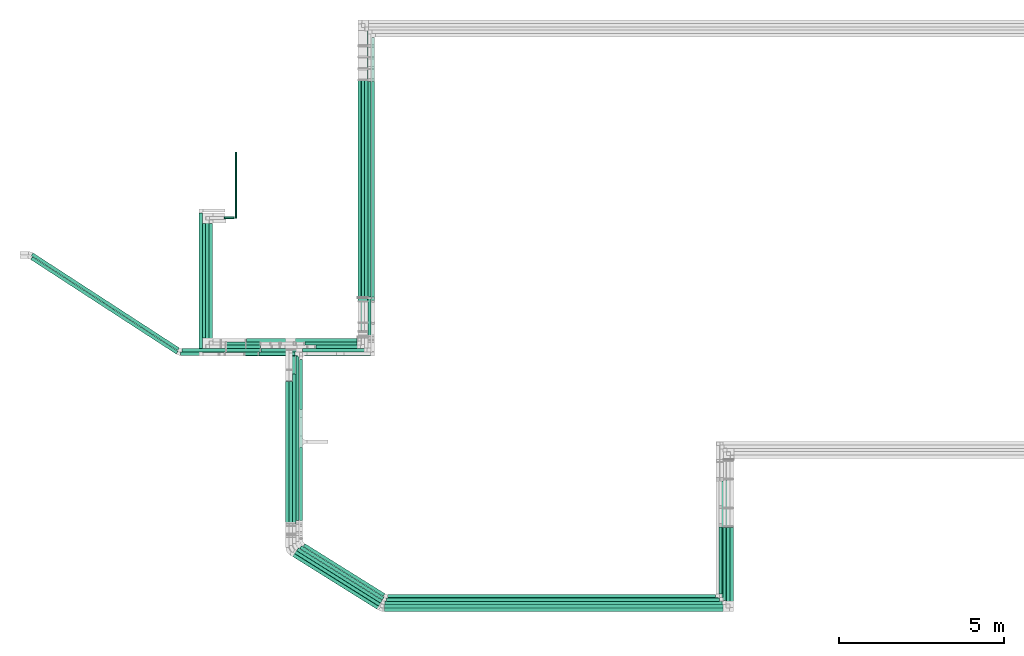
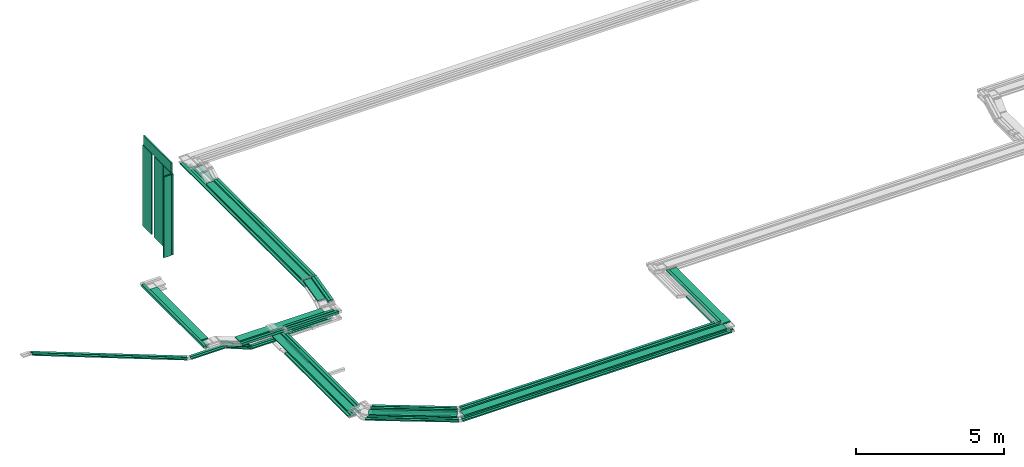
# One storey, part 1 of 18: 64 flow segments.
"""IFC2X3 building model written with IfcOpenShell, lengths in millimetres."""

from ifc_helpers import new_model, entity, si_unit, converted_unit, derived_unit, direction, frame, frame_2d, origin, origin_2d_with_axis, place, context, subcontext, project, spatial, rectangle, extrude, type_object, element, save


model = new_model("IFC2X3")

# Units and contexts
model_context = context("Model", 3, precision=0.01, world=origin(), true_north=direction((6.12303176911189e-17, 1.0)))
body_context = subcontext(model_context, "Body", "Model", "MODEL_VIEW")
ifc_project = project(units=[si_unit("LENGTHUNIT", "METRE", prefix="MILLI"), si_unit("AREAUNIT", "SQUARE_METRE"), si_unit("VOLUMEUNIT", "CUBIC_METRE"), converted_unit("PLANEANGLEUNIT", "DEGREE", entity("IfcRatioMeasure", 0.0174532925199433), si_unit("PLANEANGLEUNIT", "RADIAN"), dimensions=[0, 0, 0, 0, 0, 0, 0]), si_unit("MASSUNIT", "GRAM", prefix="KILO"), derived_unit("MASSDENSITYUNIT", [(si_unit("MASSUNIT", "GRAM", prefix="KILO"), 1), (si_unit("LENGTHUNIT", "METRE"), -3)]), derived_unit("MOMENTOFINERTIAUNIT", [(si_unit("LENGTHUNIT", "METRE"), 4)]), si_unit("TIMEUNIT", "SECOND"), si_unit("FREQUENCYUNIT", "HERTZ"), si_unit("THERMODYNAMICTEMPERATUREUNIT", "DEGREE_CELSIUS"), derived_unit("THERMALTRANSMITTANCEUNIT", [(si_unit("MASSUNIT", "GRAM", prefix="KILO"), 1), (si_unit("THERMODYNAMICTEMPERATUREUNIT", "KELVIN"), -1), (si_unit("TIMEUNIT", "SECOND"), -3)]), derived_unit("VOLUMETRICFLOWRATEUNIT", [(si_unit("LENGTHUNIT", "METRE"), 3), (si_unit("TIMEUNIT", "SECOND"), -1)]), derived_unit("MASSFLOWRATEUNIT", [(si_unit("MASSUNIT", "GRAM", prefix="KILO"), 1), (si_unit("TIMEUNIT", "SECOND"), -1)]), derived_unit("ROTATIONALFREQUENCYUNIT", [(si_unit("TIMEUNIT", "SECOND"), -1)]), si_unit("ELECTRICCURRENTUNIT", "AMPERE"), si_unit("ELECTRICVOLTAGEUNIT", "VOLT"), si_unit("POWERUNIT", "WATT"), si_unit("FORCEUNIT", "NEWTON", prefix="KILO"), si_unit("ILLUMINANCEUNIT", "LUX"), si_unit("LUMINOUSFLUXUNIT", "LUMEN"), si_unit("LUMINOUSINTENSITYUNIT", "CANDELA"), derived_unit("USERDEFINED", [(si_unit("MASSUNIT", "GRAM", prefix="KILO"), -1), (si_unit("LENGTHUNIT", "METRE"), -2), (si_unit("TIMEUNIT", "SECOND"), 3), (si_unit("LUMINOUSFLUXUNIT", "LUMEN"), 1)]), derived_unit("LINEARVELOCITYUNIT", [(si_unit("LENGTHUNIT", "METRE"), 1), (si_unit("TIMEUNIT", "SECOND"), -1)]), si_unit("PRESSUREUNIT", "PASCAL"), derived_unit("USERDEFINED", [(si_unit("LENGTHUNIT", "METRE"), -2), (si_unit("MASSUNIT", "GRAM", prefix="KILO"), 1), (si_unit("TIMEUNIT", "SECOND"), -2)]), derived_unit("LINEARFORCEUNIT", [(si_unit("MASSUNIT", "GRAM", prefix="KILO"), 1), (si_unit("LENGTHUNIT", "METRE"), 1), (si_unit("TIMEUNIT", "SECOND"), -2), (si_unit("LENGTHUNIT", "METRE"), -1)]), derived_unit("PLANARFORCEUNIT", [(si_unit("MASSUNIT", "GRAM", prefix="KILO"), 1), (si_unit("LENGTHUNIT", "METRE"), 1), (si_unit("TIMEUNIT", "SECOND"), -2), (si_unit("LENGTHUNIT", "METRE"), -2)])], contexts=[model_context])

# Site, building, storey
site_placement = place(None, frame((0.0, -0.00077364408347762, 0.0)))
site = spatial("IfcSite", under=ifc_project, at=site_placement, CompositionType="ELEMENT")
building_placement = place(site_placement, origin())
building = spatial("IfcBuilding", under=site, at=building_placement, CompositionType="ELEMENT")
storey_placement = place(building_placement, frame((0.0, 0.0, 19800.0)))
storey = spatial("IfcBuildingStorey", under=building, at=storey_placement, CompositionType="ELEMENT", Elevation=19800.0)

# Flow segments
cable_carrier_segment_type_1 = type_object("IfcCableCarrierSegmentType", PredefinedType="CABLETRAYSEGMENT")
flow_segment_1_placement = place(storey_placement, frame((20190.2168010831, 11603.0012765651, 3300.0)))
element("IfcFlowSegment", 1, at=flow_segment_1_placement, inside=storey, type_object=cable_carrier_segment_type_1, context=body_context, shape_type="SweptSolid", body=[
    extrude(rectangle(XDim=6551.54787533766, YDim=300.000000000001, at=frame_2d((9.09494701772928e-13, -2.17426077142591e-12), x_axis=(1.0, 0.0))), frame((150.0, 3275.77393766883, 0.0), z_axis=(0.0, 0.0, 1.0), x_axis=(0.0, 1.0, 0.0)), (0.0, 0.0, 1.0), 49.9999999999973),
])
flow_segment_2_placement = place(storey_placement, frame((20495.2168010831, 11609.1230030289, 3300.0)))
element("IfcFlowSegment", 2, at=flow_segment_2_placement, inside=storey, type_object=cable_carrier_segment_type_1, context=body_context, shape_type="SweptSolid", body=[
    extrude(rectangle(XDim=6531.55992167095, YDim=100.000000000003, at=frame_2d((1.13686837721616e-12, -2.16715534406831e-12), x_axis=(1.0, 0.0))), frame((50.0, 3265.77996083547, 0.0), z_axis=(0.0, 0.0, 1.0), x_axis=(0.0, 1.0, 0.0)), (0.0, 0.0, 1.0), 100.000000000003),
])
flow_segment_3_placement = place(storey_placement, frame((20600.2168010831, 11501.2511492112, 3100.0)))
element("IfcFlowSegment", 3, at=flow_segment_3_placement, inside=storey, type_object=cable_carrier_segment_type_1, context=body_context, shape_type="SweptSolid", body=[
    extrude(rectangle(XDim=7968.74949015567, YDim=100.000000000003, at=frame_2d((0.0, -2.16715534406831e-12), x_axis=(1.0, 0.0))), frame((50.0, 3984.37474507783, 0.0), z_axis=(0.0, 0.0, 1.0), x_axis=(0.0, -1.0, 0.0)), (0.0, 0.0, 1.0), 100.000000000003),
])
flow_segment_4_placement = place(storey_placement, frame((20190.2168010831, 11493.5128111901, 3100.0)))
element("IfcFlowSegment", 4, at=flow_segment_4_placement, inside=storey, type_object=cable_carrier_segment_type_1, context=body_context, shape_type="SweptSolid", body=[
    extrude(rectangle(XDim=8386.48782817678, YDim=100.000000000003, at=frame_2d((9.09494701772928e-13, -2.16715534406831e-12), x_axis=(1.0, 0.0))), frame((50.0, 4193.24391408839, 0.0), z_axis=(0.0, 0.0, 1.0), x_axis=(0.0, -1.0, 0.0)), (0.0, 0.0, 1.0), 49.9999999999973),
])
flow_segment_5_placement = place(storey_placement, frame((20295.2168010831, 11493.5128111901, 3100.0)))
element("IfcFlowSegment", 5, at=flow_segment_5_placement, inside=storey, type_object=cable_carrier_segment_type_1, context=body_context, shape_type="SweptSolid", body=[
    extrude(rectangle(XDim=8281.48782817677, YDim=100.000000000003, at=frame_2d((9.09494701772928e-13, 0.0), x_axis=(1.0, 0.0))), frame((50.0, 4140.74391408839, 0.0), z_axis=(0.0, 0.0, 1.0), x_axis=(0.0, -1.0, 0.0)), (0.0, 0.0, 1.0), 49.9999999999973),
])
flow_segment_6_placement = place(storey_placement, frame((20400.2168010831, 11493.5128111901, 3100.0)))
element("IfcFlowSegment", 6, at=flow_segment_6_placement, inside=storey, type_object=cable_carrier_segment_type_1, context=body_context, shape_type="SweptSolid", body=[
    extrude(rectangle(XDim=8176.48782817679, YDim=100.000000000003, at=frame_2d((0.0, 2.16715534406831e-12), x_axis=(1.0, 0.0))), frame((50.0, 4088.2439140884, 0.0), z_axis=(0.0, 0.0, 1.0), x_axis=(0.0, -1.0, 0.0)), (0.0, 0.0, 1.0), 49.9999999999973),
])
flow_segment_7_placement = place(storey_placement, frame((18157.5440474966, 10050.1297639901, 2900.0)))
element("IfcFlowSegment", 7, at=flow_segment_7_placement, inside=storey, type_object=cable_carrier_segment_type_1, context=body_context, shape_type="SweptSolid", body=[
    extrude(rectangle(XDim=2012.67275358651, YDim=300.000000000001, at=frame_2d((-1.08002495835535e-12, 0.0), x_axis=(1.0, 0.0))), frame((1006.33637679325, 150.0, 0.0), z_axis=(0.0, 0.0, 1.0), x_axis=(-1.0, 0.0, 0.0)), (0.0, 0.0, 1.0), 49.9999999999973),
])
flow_segment_8_placement = place(storey_placement, frame((18522.1440474967, 9944.23549574398, 2900.0)))
element("IfcFlowSegment", 8, at=flow_segment_8_placement, inside=storey, type_object=cable_carrier_segment_type_1, context=body_context, shape_type="SweptSolid", body=[
    extrude(rectangle(XDim=1953.07275358647, YDim=99.9999999999989, at=frame_2d((0.0, 1.08357767203415e-12), x_axis=(1.0, 0.0))), frame((976.536376793235, 50.0, 0.0), z_axis=(0.0, 0.0, 1.0), x_axis=(-1.0, 0.0, 0.0)), (0.0, 0.0, 1.0), 100.000000000003),
])
flow_segment_9_placement = place(storey_placement, frame((16789.0007686029, 9824.22079653058, 2900.0)))
element("IfcFlowSegment", 9, at=flow_segment_9_placement, inside=storey, type_object=cable_carrier_segment_type_1, context=body_context, shape_type="SweptSolid", body=[
    extrude(rectangle(XDim=1677.74327889368, YDim=99.9999999999989, at=frame_2d((1.08002495835535e-12, 0.0), x_axis=(1.0, 0.0))), frame((838.871639446842, 50.0, 0.0)), (0.0, 0.0, 1.0), 100.000000000003),
])
flow_segment_10_placement = place(storey_placement, frame((17191.3522289193, 9840.22583236336, 2600.0)))
element("IfcFlowSegment", 10, at=flow_segment_10_placement, inside=storey, type_object=cable_carrier_segment_type_1, context=body_context, shape_type="SweptSolid", body=[
    extrude(rectangle(XDim=1095.79181857732, YDim=99.9999999999989, at=frame_2d((1.08002495835535e-12, 0.0), x_axis=(1.0, 0.0))), frame((547.895909288659, 50.0, 0.0)), (0.0, 0.0, 1.0), 49.9999999999973),
])
flow_segment_11_placement = place(storey_placement, frame((17256.5890277902, 9944.23549574399, 2600.0)))
element("IfcFlowSegment", 11, at=flow_segment_11_placement, inside=storey, type_object=cable_carrier_segment_type_1, context=body_context, shape_type="SweptSolid", body=[
    extrude(rectangle(XDim=3123.62777329295, YDim=99.9999999999989, at=frame_2d((1.13686837721616e-12, 0.0), x_axis=(1.0, 0.0))), frame((1561.81388664648, 50.0, 0.0), z_axis=(0.0, 0.0, 1.0), x_axis=(-1.0, 0.0, 0.0)), (0.0, 0.0, 1.0), 50.0000000000016),
])
flow_segment_12_placement = place(storey_placement, frame((21062.5934276672, 2392.26804939264, 3200.0)))
element("IfcFlowSegment", 12, at=flow_segment_12_placement, inside=storey, type_object=cable_carrier_segment_type_1, context=body_context, shape_type="SweptSolid", body=[
    extrude(rectangle(XDim=10078.0137037583, YDim=100.0, at=origin_2d_with_axis()), frame((5039.00685187917, 50.0, 0.0), z_axis=(0.0, 0.0, 1.0), x_axis=(-1.0, 0.0, 0.0)), (0.0, 0.0, 1.0), 100.000000000008),
])
flow_segment_13_placement = place(storey_placement, frame((20986.6526743411, 2192.26804939263, 3000.0)))
element("IfcFlowSegment", 13, at=flow_segment_13_placement, inside=storey, type_object=cable_carrier_segment_type_1, context=body_context, shape_type="SweptSolid", body=[
    extrude(rectangle(XDim=10354.846485042, YDim=100.0, at=frame_2d((1.81898940354586e-12, 1.3855583347322e-13), x_axis=(1.0, 0.0))), frame((5177.42324252102, 50.0, 0.0), z_axis=(0.0, 0.0, 1.0), x_axis=(-1.0, 0.0, 0.0)), (0.0, 0.0, 1.0), 49.9999999999973),
])
flow_segment_14_placement = place(storey_placement, frame((18007.1440474966, 4795.40856656226, 2800.0)))
element("IfcFlowSegment", 14, at=flow_segment_14_placement, inside=storey, type_object=cable_carrier_segment_type_1, context=body_context, shape_type="SweptSolid", body=[
    extrude(rectangle(XDim=5199.72119742787, YDim=300.000000000001, at=frame_2d((4.54747350886464e-13, 0.0), x_axis=(1.0, 0.0))), frame((150.0, 2599.86059871393, 0.0), z_axis=(0.0, 0.0, 1.0), x_axis=(0.0, 1.0, 0.0)), (0.0, 0.0, 1.0), 49.9999999999973),
])
flow_segment_15_placement = place(storey_placement, frame((18312.1440474966, 4839.9270477843, 2800.0)))
element("IfcFlowSegment", 15, at=flow_segment_15_placement, inside=storey, type_object=cable_carrier_segment_type_1, context=body_context, shape_type="SweptSolid", body=[
    extrude(rectangle(XDim=5127.14874316907, YDim=99.9999999999989, at=frame_2d((-2.27373675443232e-13, 0.0), x_axis=(1.0, 0.0))), frame((50.0, 2563.57437158454, 0.0), z_axis=(0.0, 0.0, 1.0), x_axis=(0.0, 1.0, 0.0)), (0.0, 0.0, 1.0), 100.000000000003),
])
flow_segment_16_placement = place(storey_placement, frame((18417.1440474966, 8193.9505516651, 2600.0)))
element("IfcFlowSegment", 16, at=flow_segment_16_placement, inside=storey, type_object=cable_carrier_segment_type_1, context=body_context, shape_type="SweptSolid", body=[
    extrude(rectangle(XDim=1516.27528069827, YDim=99.9999999999989, at=frame_2d((0.0, -1.08357767203415e-12), x_axis=(1.0, 0.0))), frame((50.0, 758.137640349134, 0.0), z_axis=(0.0, 0.0, 1.0), x_axis=(0.0, -1.0, 0.0)), (0.0, 0.0, 1.0), 50.0000000000016),
])
flow_segment_17_placement = place(storey_placement, frame((18007.1440474966, 4732.08348247397, 2600.0)))
element("IfcFlowSegment", 17, at=flow_segment_17_placement, inside=storey, type_object=cable_carrier_segment_type_1, context=body_context, shape_type="SweptSolid", body=[
    extrude(rectangle(XDim=4319.69591813559, YDim=99.9999999999989, at=frame_2d((6.82121026329696e-13, 0.0), x_axis=(1.0, 0.0))), frame((50.0, 2159.8479590678, 0.0), z_axis=(0.0, 0.0, 1.0), x_axis=(0.0, 1.0, 0.0)), (0.0, 0.0, 1.0), 49.9999999999973),
])
flow_segment_18_placement = place(storey_placement, frame((18112.1440474966, 4732.08348247398, 2600.0)))
element("IfcFlowSegment", 18, at=flow_segment_18_placement, inside=storey, type_object=cable_carrier_segment_type_1, context=body_context, shape_type="SweptSolid", body=[
    extrude(rectangle(XDim=4319.6959181356, YDim=99.9999999999989, at=origin_2d_with_axis()), frame((50.0, 2159.8479590678, 0.0), z_axis=(0.0, 0.0, 1.0), x_axis=(0.0, 1.0, 0.0)), (0.0, 0.0, 1.0), 49.9999999999973),
])
flow_segment_19_placement = place(storey_placement, frame((18217.1440474966, 4732.08348247398, 2600.0)))
element("IfcFlowSegment", 19, at=flow_segment_19_placement, inside=storey, type_object=cable_carrier_segment_type_1, context=body_context, shape_type="SweptSolid", body=[
    extrude(rectangle(XDim=4546.36734918782, YDim=99.9999999999989, at=origin_2d_with_axis()), frame((50.0, 2273.18367459391, 0.0), z_axis=(0.0, 0.0, 1.0), x_axis=(0.0, 1.0, 0.0)), (0.0, 0.0, 1.0), 49.9999999999973),
])
flow_segment_20_placement = place(storey_placement, frame((31125.1088789037, 2617.26804939265, 3000.0)))
element("IfcFlowSegment", 20, at=flow_segment_20_placement, inside=storey, type_object=cable_carrier_segment_type_1, context=body_context, shape_type="SweptSolid", body=[
    extrude(rectangle(XDim=2031.89362716771, YDim=100.000000000003, at=frame_2d((-2.27373675443232e-13, 2.16715534406831e-12), x_axis=(1.0, 0.0))), frame((50.0, 1015.94681358385, 0.0), z_axis=(0.0, 0.0, 1.0), x_axis=(0.0, 1.0, 0.0)), (0.0, 0.0, 1.0), 99.9999999999989),
])
flow_segment_21_placement = place(storey_placement, frame((31249.2859471786, 2417.26804939264, 3000.0)))
element("IfcFlowSegment", 21, at=flow_segment_21_placement, inside=storey, type_object=cable_carrier_segment_type_1, context=body_context, shape_type="SweptSolid", body=[
    extrude(rectangle(XDim=2211.95486644315, YDim=100.000000000003, at=frame_2d((2.27373675443232e-13, -2.16715534406831e-12), x_axis=(1.0, 0.0))), frame((50.0, 1105.97743322157, 0.0), z_axis=(0.0, 0.0, 1.0), x_axis=(0.0, 1.0, 0.0)), (0.0, 0.0, 1.0), 49.9999999999973),
])
flow_segment_22_placement = place(storey_placement, frame((31361.4991593832, 2312.26804939263, 3000.0)))
element("IfcFlowSegment", 22, at=flow_segment_22_placement, inside=storey, type_object=cable_carrier_segment_type_1, context=body_context, shape_type="SweptSolid", body=[
    extrude(rectangle(XDim=2316.95486644316, YDim=100.000000000003, at=frame_2d((-2.27373675443232e-13, 0.0), x_axis=(1.0, 0.0))), frame((50.0, 1158.47743322158, 0.0), z_axis=(0.0, 0.0, 1.0), x_axis=(0.0, -1.0, 0.0)), (0.0, 0.0, 1.0), 49.9999999999973),
])
flow_segment_23_placement = place(storey_placement, frame((31471.4335639594, 2207.26804939264, 3000.0)))
element("IfcFlowSegment", 23, at=flow_segment_23_placement, inside=storey, type_object=cable_carrier_segment_type_1, context=body_context, shape_type="SweptSolid", body=[
    extrude(rectangle(XDim=2421.95486644317, YDim=100.000000000003, at=frame_2d((1.13686837721616e-13, 2.16715534406831e-12), x_axis=(1.0, 0.0))), frame((50.0, 1210.97743322158, 0.0), z_axis=(0.0, 0.0, 1.0), x_axis=(0.0, 1.0, 0.0)), (0.0, 0.0, 1.0), 49.9999999999973),
])
flow_segment_24_placement = place(storey_placement, frame((31271.4335639593, 2407.26804939264, 3200.0)))
element("IfcFlowSegment", 24, at=flow_segment_24_placement, inside=storey, type_object=cable_carrier_segment_type_1, context=body_context, shape_type="SweptSolid", body=[
    extrude(rectangle(XDim=3662.65856661165, YDim=300.000000000001, at=frame_2d((2.27373675443232e-13, 0.0), x_axis=(1.0, 0.0))), frame((150.0, 1831.32928330583, 0.0), z_axis=(0.0, 0.0, 1.0), x_axis=(0.0, 1.0, 0.0)), (0.0, 0.0, 1.0), 49.9999999999973),
])
flow_segment_25_placement = place(storey_placement, frame((31160.6071314255, 2512.26804939264, 3200.0)))
element("IfcFlowSegment", 25, at=flow_segment_25_placement, inside=storey, type_object=cable_carrier_segment_type_1, context=body_context, shape_type="SweptSolid", body=[
    extrude(rectangle(XDim=3526.8936271677, YDim=100.000000000003, at=frame_2d((5.6843418860808e-13, 0.0), x_axis=(1.0, 0.0))), frame((50.0, 1763.44681358385, 0.0), z_axis=(0.0, 0.0, 1.0), x_axis=(0.0, 1.0, 0.0)), (0.0, 0.0, 1.0), 100.000000000003),
])
flow_segment_26_placement = place(storey_placement, frame((21097.2879950322, 2497.26804939265, 3000.0)))
element("IfcFlowSegment", 26, at=flow_segment_26_placement, inside=storey, type_object=cable_carrier_segment_type_1, context=body_context, shape_type="SweptSolid", body=[
    extrude(rectangle(XDim=10007.8208838715, YDim=100.0, at=frame_2d((-1.81898940354586e-12, 2.73558953267639e-13), x_axis=(1.0, 0.0))), frame((5003.91044193577, 50.0, 0.0), z_axis=(0.0, 0.0, 1.0), x_axis=(-1.0, 0.0, 0.0)), (0.0, 0.0, 1.0), 100.000000000003),
])
flow_segment_27_placement = place(storey_placement, frame((18430.5122795345, 2430.78594461788, 3200.0)))
element("IfcFlowSegment", 27, at=flow_segment_27_placement, inside=storey, type_object=cable_carrier_segment_type_1, context=body_context, shape_type="SweptSolid", body=[
    extrude(rectangle(XDim=2945.29672939392, YDim=100.000000000004, at=frame_2d((1.13686837721616e-13, -2.06057393370429e-13), x_axis=(1.0, 0.0))), frame((1275.37260520079, 822.787142702276, 0.0), z_axis=(0.0, 0.0, 1.0), x_axis=(-0.848048096156423, 0.52991926423321, 0.0)), (0.0, 0.0, 1.0), 100.000000000003),
])
flow_segment_28_placement = place(storey_placement, frame((21014.2462153962, 2297.26804939264, 3000.0)))
element("IfcFlowSegment", 28, at=flow_segment_28_placement, inside=storey, type_object=cable_carrier_segment_type_1, context=body_context, shape_type="SweptSolid", body=[
    extrude(rectangle(XDim=10215.0397317824, YDim=100.0, at=frame_2d((2.27373675443232e-12, 0.0), x_axis=(1.0, 0.0))), frame((5107.51986589121, 50.0, 0.0), z_axis=(0.0, 0.0, 1.0), x_axis=(-1.0, 0.0, 0.0)), (0.0, 0.0, 1.0), 49.9999999999973),
])
flow_segment_29_placement = place(storey_placement, frame((20950.0357474934, 2087.26804939264, 3000.0)))
element("IfcFlowSegment", 29, at=flow_segment_29_placement, inside=storey, type_object=cable_carrier_segment_type_1, context=body_context, shape_type="SweptSolid", body=[
    extrude(rectangle(XDim=10501.3978164659, YDim=100.0, at=frame_2d((-2.27373675443232e-12, 0.0), x_axis=(1.0, 0.0))), frame((5250.69890823296, 50.0, 0.0), z_axis=(0.0, 0.0, 1.0), x_axis=(-1.0, 0.0, 0.0)), (0.0, 0.0, 1.0), 49.9999999999973),
])
flow_segment_30_placement = place(storey_placement, frame((18125.5122795345, 2125.78594461787, 3000.0)))
element("IfcFlowSegment", 30, at=flow_segment_30_placement, inside=storey, type_object=cable_carrier_segment_type_1, context=body_context, shape_type="SweptSolid", body=[
    extrude(rectangle(XDim=3172.2205568259, YDim=100.000000000005, at=frame_2d((1.02318153949454e-12, 4.05009359383257e-13), x_axis=(1.0, 0.0))), frame((1371.5937651139, 882.912796537145, 0.0), z_axis=(0.0, 0.0, 1.0), x_axis=(-0.848048096156423, 0.52991926423321, 0.0)), (0.0, 0.0, 1.0), 49.9999999999973),
])
flow_segment_31_placement = place(storey_placement, frame((21002.320578681, 2087.26804939264, 3200.0)))
element("IfcFlowSegment", 31, at=flow_segment_31_placement, inside=storey, type_object=cable_carrier_segment_type_1, context=body_context, shape_type="SweptSolid", body=[
    extrude(rectangle(XDim=10249.1129852784, YDim=300.0, at=origin_2d_with_axis()), frame((5124.55649263918, 150.0, 0.0), z_axis=(0.0, 0.0, 1.0), x_axis=(-1.0, 0.0, 0.0)), (0.0, 0.0, 1.0), 49.9999999999973),
])
flow_segment_32_placement = place(storey_placement, frame((21092.9161228958, 2499.99989830113, 3200.0)))
element("IfcFlowSegment", 32, at=flow_segment_32_placement, inside=storey, type_object=cable_carrier_segment_type_1, context=body_context, shape_type="SweptSolid", body=[
    extrude(rectangle(XDim=9934.97609200436, YDim=100.0, at=frame_2d((0.0, 2.73558953267639e-13), x_axis=(1.0, 0.0))), frame((4967.48804600218, 50.0, 0.0), z_axis=(0.0, 0.0, 1.0), x_axis=(-1.0, 0.0, 0.0)), (0.0, 0.0, 1.0), 100.000000000008),
])
flow_segment_33_placement = place(storey_placement, frame((18535.5122795345, 2538.51779352637, 3200.0)))
element("IfcFlowSegment", 33, at=flow_segment_33_placement, inside=storey, type_object=cable_carrier_segment_type_1, context=body_context, shape_type="SweptSolid", body=[
    extrude(rectangle(XDim=2857.23886438621, YDim=100.000000000005, at=frame_2d((-6.82121026329696e-13, -1.08357767203415e-12), x_axis=(1.0, 0.0))), frame((1238.03395281509, 799.455363184868, 0.0), z_axis=(0.0, 0.0, 1.0), x_axis=(-0.84804809615642, 0.529919264233215, 0.0)), (0.0, 0.0, 1.0), 100.000000000003),
])
flow_segment_34_placement = place(storey_placement, frame((18230.5122795345, 2230.78594461787, 3000.0)))
element("IfcFlowSegment", 34, at=flow_segment_34_placement, inside=storey, type_object=cable_carrier_segment_type_1, context=body_context, shape_type="SweptSolid", body=[
    extrude(rectangle(XDim=3091.5847138092, YDim=100.000000000005, at=frame_2d((4.54747350886464e-13, -7.46069872548105e-13), x_axis=(1.0, 0.0))), frame((1337.40222853776, 861.547553236025, 0.0), z_axis=(0.0, 0.0, 1.0), x_axis=(-0.848048096156424, 0.529919264233208, 0.0)), (0.0, 0.0, 1.0), 49.9999999999973),
])
flow_segment_35_placement = place(storey_placement, frame((18335.5122795345, 2335.78594461787, 3000.0)))
element("IfcFlowSegment", 35, at=flow_segment_35_placement, inside=storey, type_object=cable_carrier_segment_type_1, context=body_context, shape_type="SweptSolid", body=[
    extrude(rectangle(XDim=3000.30868914057, YDim=100.000000000005, at=frame_2d((-6.82121026329696e-13, -8.13571432445315e-13), x_axis=(1.0, 0.0))), frame((1298.69899906528, 837.363091318759, 0.0), z_axis=(0.0, 0.0, 1.0), x_axis=(-0.848048096156424, 0.529919264233208, 0.0)), (0.0, 0.0, 1.0), 49.9999999999973),
])
flow_segment_36_placement = place(storey_placement, frame((18535.5122795345, 2535.78594461788, 3000.0)))
element("IfcFlowSegment", 36, at=flow_segment_36_placement, inside=storey, type_object=cable_carrier_segment_type_1, context=body_context, shape_type="SweptSolid", body=[
    extrude(rectangle(XDim=2862.39408159168, YDim=99.9999999999956, at=frame_2d((2.50111042987555e-12, 2.16715534406831e-12), x_axis=(1.0, 0.0))), frame((1240.21988888329, 800.821287639093, 0.0), z_axis=(0.0, 0.0, 1.0), x_axis=(-0.848048096156425, 0.529919264233207, 0.0)), (0.0, 0.0, 1.0), 100.000000000003),
])
flow_segment_37_placement = place(storey_placement, frame((18219.5284266878, 2156.17632538658, 3200.0)))
element("IfcFlowSegment", 37, at=flow_segment_37_placement, inside=storey, type_object=cable_carrier_segment_type_1, context=body_context, shape_type="SweptSolid", body=[
    extrude(rectangle(XDim=2998.03801991332, YDim=300.000000000004, at=frame_2d((1.13686837721616e-13, -9.9475983006414e-14), x_axis=(1.0, 0.0))), frame((1350.72810713102, 921.566265251291, 0.0), z_axis=(0.0, 0.0, 1.0), x_axis=(-0.848048096156424, 0.529919264233208, 0.0)), (0.0, 0.0, 1.0), 49.9999999999973),
])
flow_segment_38_placement = place(storey_placement, frame((20600.2168010831, 11609.1230030289, 3300.0)))
element("IfcFlowSegment", 38, at=flow_segment_38_placement, inside=storey, type_object=cable_carrier_segment_type_1, context=body_context, shape_type="SweptSolid", body=[
    extrude(rectangle(XDim=6531.55992167089, YDim=100.000000000003, at=frame_2d((1.13686837721616e-12, 0.0), x_axis=(1.0, 0.0))), frame((50.0, 3265.77996083544, 0.0), z_axis=(0.0, 0.0, 1.0), x_axis=(0.0, 1.0, 0.0)), (0.0, 0.0, 1.0), 100.000000000003),
])
flow_segment_39_placement = place(storey_placement, frame((20600.2168010831, 10390.0758652299, 3005.86472358247)))
element("IfcFlowSegment", 39, at=flow_segment_39_placement, inside=storey, type_object=cable_carrier_segment_type_1, context=body_context, shape_type="SweptSolid", body=[
    extrude(rectangle(XDim=99.9999999999975, YDim=1207.4663906893, at=frame_2d((1.53477230924182e-12, 1.83675297193986e-12), x_axis=(0.0, 1.0))), frame((0.0, 597.962965704819, 194.175338588972), z_axis=(1.0, 0.0, 0.0), x_axis=(0.0, 0.970462347809245, 0.241252630005495)), (0.0, 0.0, 1.0), 100.000000000003),
])
flow_segment_40_placement = place(storey_placement, frame((20495.2168010831, 10390.07586523, 3005.86472358247)))
element("IfcFlowSegment", 40, at=flow_segment_40_placement, inside=storey, type_object=cable_carrier_segment_type_1, context=body_context, shape_type="SweptSolid", body=[
    extrude(rectangle(XDim=99.999999999998, YDim=1207.46639068923, at=frame_2d((-1.59161572810262e-12, -1.85451654033386e-12), x_axis=(0.0, 1.0))), frame((0.0, 597.962965704783, 194.175338588963), z_axis=(1.0, 0.0, 0.0), x_axis=(0.0, -0.970462347809245, -0.241252630005494)), (0.0, 0.0, 1.0), 99.9999999999989),
])
flow_segment_41_placement = place(storey_placement, frame((20190.2168010831, 10586.8678327632, 3052.54853317503)))
element("IfcFlowSegment", 41, at=flow_segment_41_placement, inside=storey, type_object=cable_carrier_segment_type_1, context=body_context, shape_type="SweptSolid", body=[
    extrude(rectangle(XDim=50.0000000000032, YDim=1017.02134440409, at=frame_2d((1.56319401867222e-12, 1.83497661510046e-12), x_axis=(0.0, 1.0))), frame((0.0, 499.52177658139, 146.941095749847), z_axis=(1.0, 0.0, 0.0), x_axis=(0.0, -0.970462347809243, -0.241252630005501)), (0.0, 0.0, 1.0), 300.000000000001),
])
flow_segment_42_placement = place(storey_placement, frame((16196.7374602901, 10152.8422557896, 2607.02137102248)))
element("IfcFlowSegment", 42, at=flow_segment_42_placement, inside=storey, type_object=cable_carrier_segment_type_1, context=body_context, shape_type="SweptSolid", body=[
    extrude(rectangle(XDim=49.9999999999978, YDim=99.9999999999989, at=frame_2d((-3.85469434149854e-13, 0.0), x_axis=(1.0, 0.0))), frame((8.90017435141874, 50.0, 412.595175502609), z_axis=(0.934483298097407, 0.0, -0.356006974056679), x_axis=(0.356006974056679, 0.0, 0.934483298097407)), (0.0, 0.0, 1.0), 1093.32996658713),
])
for number, where in (
    (43, (16196.7374602901, 10049.8208448265, 2607.0213710225)),
    (44, (16196.7374602901, 9944.23549574399, 2607.0213710225)),
):
    element("IfcFlowSegment", number, at=place(storey_placement, frame(where)), inside=storey, type_object=cable_carrier_segment_type_1, context=body_context, shape_type="SweptSolid", body=[
        extrude(rectangle(XDim=49.9999999999978, YDim=99.9999999999989, at=origin_2d_with_axis()), frame((8.90017435141657, 50.0, 412.595175502583), z_axis=(0.934483298097407, 0.0, -0.356006974056679), x_axis=(0.356006974056679, 0.0, 0.934483298097407)), (0.0, 0.0, 1.0), 1093.32996658708),
    ])
flow_segment_43_placement = place(storey_placement, frame((14864.6010060019, 9944.23549574399, 3000.0)))
element("IfcFlowSegment", 45, at=flow_segment_43_placement, inside=storey, type_object=cable_carrier_segment_type_1, context=body_context, shape_type="SweptSolid", body=[
    extrude(rectangle(XDim=1311.78382857603, YDim=99.9999999999989, at=frame_2d((1.08002495835535e-12, 0.0), x_axis=(1.0, 0.0))), frame((655.891914288016, 50.0, 0.0), z_axis=(0.0, 0.0, 1.0), x_axis=(-1.0, 0.0, 0.0)), (0.0, 0.0, 1.0), 49.9999999999973),
])
flow_segment_44_placement = place(storey_placement, frame((16163.815818071, 9840.22583236336, 2607.47729251877)))
element("IfcFlowSegment", 46, at=flow_segment_44_placement, inside=storey, type_object=cable_carrier_segment_type_1, context=body_context, shape_type="SweptSolid", body=[
    extrude(rectangle(XDim=49.9999999999963, YDim=99.9999999999989, at=origin_2d_with_axis()), frame((9.21591270529165, 50.0, 415.203396210156), z_axis=(0.929573625278576, 0.0, -0.368636508211606), x_axis=(0.368636508211606, 0.0, 0.929573625278576)), (0.0, 0.0, 1.0), 1063.2806215525),
])
flow_segment_45_placement = place(storey_placement, frame((18467.5440474966, 9824.2207965306, 2900.0)))
element("IfcFlowSegment", 47, at=flow_segment_45_placement, inside=storey, type_object=cable_carrier_segment_type_1, context=body_context, shape_type="SweptSolid", body=[
    extrude(rectangle(XDim=2112.67275358652, YDim=99.9999999999989, at=frame_2d((2.1600499167107e-12, -1.08357767203415e-12), x_axis=(1.0, 0.0))), frame((1056.33637679327, 50.0, 0.0), z_axis=(0.0, 0.0, 1.0), x_axis=(-1.0, 0.0, 0.0)), (0.0, 0.0, 1.0), 100.000000000003),
])
flow_segment_46_placement = place(storey_placement, frame((18417.1440474966, 4776.60196369602, 2600.0)))
element("IfcFlowSegment", 48, at=flow_segment_46_placement, inside=storey, type_object=cable_carrier_segment_type_1, context=body_context, shape_type="SweptSolid", body=[
    extrude(rectangle(XDim=2267.1487431691, YDim=99.9999999999989, at=frame_2d((2.27373675443232e-13, 0.0), x_axis=(1.0, 0.0))), frame((50.0, 1133.57437158455, 0.0), z_axis=(0.0, 0.0, 1.0), x_axis=(0.0, 1.0, 0.0)), (0.0, 0.0, 1.0), 100.000000000003),
])
flow_segment_47_placement = place(storey_placement, frame((18917.4576884505, 10049.8208448265, 2600.0)))
element("IfcFlowSegment", 49, at=flow_segment_47_placement, inside=storey, type_object=cable_carrier_segment_type_1, context=body_context, shape_type="SweptSolid", body=[
    extrude(rectangle(XDim=1357.75911263266, YDim=99.9999999999989, at=frame_2d((1.08002495835535e-12, 0.0), x_axis=(1.0, 0.0))), frame((678.87955631633, 50.0, 0.0), z_axis=(0.0, 0.0, 1.0), x_axis=(-1.0, 0.0, 0.0)), (0.0, 0.0, 1.0), 49.9999999999973),
])
flow_segment_48_placement = place(storey_placement, frame((18587.9738423556, 10152.8422557896, 2600.0)))
element("IfcFlowSegment", 50, at=flow_segment_48_placement, inside=storey, type_object=cable_carrier_segment_type_1, context=body_context, shape_type="SweptSolid", body=[
    extrude(rectangle(XDim=1582.24295872755, YDim=99.9999999999989, at=frame_2d((-1.08002495835535e-12, 0.0), x_axis=(1.0, 0.0))), frame((791.121479363777, 50.0, 0.0), z_axis=(0.0, 0.0, 1.0), x_axis=(-1.0, 0.0, 0.0)), (0.0, 0.0, 1.0), 49.9999999999973),
])
flow_segment_49_placement = place(storey_placement, frame((16817.9800575676, 10050.1297639901, 2900.0)))
element("IfcFlowSegment", 51, at=flow_segment_49_placement, inside=storey, type_object=cable_carrier_segment_type_1, context=body_context, shape_type="SweptSolid", body=[
    extrude(rectangle(XDim=1338.76398992904, YDim=300.000000000001, at=frame_2d((2.1600499167107e-12, -1.08002495835535e-12), x_axis=(1.0, 0.0))), frame((669.381994964523, 150.0, 0.0)), (0.0, 0.0, 1.0), 50.0000000000016),
])
flow_segment_50_placement = place(storey_placement, frame((15490.0002685547, 10370.1297639901, 3200.0)))
element("IfcFlowSegment", 52, at=flow_segment_50_placement, inside=storey, type_object=cable_carrier_segment_type_1, context=body_context, shape_type="SweptSolid", body=[
    extrude(rectangle(XDim=3460.0, YDim=300.000000000001, at=frame_2d((-1.13686837721616e-12, -1.08002495835535e-12), x_axis=(1.0, 0.0))), frame((150.0, 1730.0, 0.0), z_axis=(0.0, 0.0, 1.0), x_axis=(0.0, 1.0, 0.0)), (0.0, 0.0, 1.0), 49.9999999999973),
])
flow_segment_51_placement = place(storey_placement, frame((15378.6244304067, 9944.2207965306, 3200.0)))
element("IfcFlowSegment", 53, at=flow_segment_51_placement, inside=storey, type_object=cable_carrier_segment_type_1, context=body_context, shape_type="SweptSolid", body=[
    extrude(rectangle(XDim=4216.00503583277, YDim=99.9999999999989, at=origin_2d_with_axis()), frame((50.0, 2108.00251791639, 0.0), z_axis=(0.0, 0.0, 1.0), x_axis=(0.0, 1.0, 0.0)), (0.0, 0.0, 1.0), 100.000000000003),
])
flow_segment_52_placement = place(storey_placement, frame((15690.0002685547, 10272.8422557896, 3000.0)))
element("IfcFlowSegment", 54, at=flow_segment_52_placement, inside=storey, type_object=cable_carrier_segment_type_1, context=body_context, shape_type="SweptSolid", body=[
    extrude(rectangle(XDim=3557.28750820052, YDim=99.9999999999989, at=frame_2d((-1.13686837721616e-12, 0.0), x_axis=(1.0, 0.0))), frame((50.0, 1778.64375410026, 0.0), z_axis=(0.0, 0.0, 1.0), x_axis=(0.0, 1.0, 0.0)), (0.0, 0.0, 1.0), 49.9999999999973),
])
flow_segment_53_placement = place(storey_placement, frame((15581.7727830703, 10169.8208448265, 3000.0)))
element("IfcFlowSegment", 55, at=flow_segment_53_placement, inside=storey, type_object=cable_carrier_segment_type_1, context=body_context, shape_type="SweptSolid", body=[
    extrude(rectangle(XDim=3765.11562472394, YDim=99.9999999999989, at=origin_2d_with_axis()), frame((50.0, 1882.55781236197, 0.0), z_axis=(0.0, 0.0, 1.0), x_axis=(0.0, 1.0, 0.0)), (0.0, 0.0, 1.0), 49.9999999999973),
])
flow_segment_54_placement = place(storey_placement, frame((10298.829066932, 9985.11249279265, 3000.0)))
element("IfcFlowSegment", 56, at=flow_segment_54_placement, inside=storey, type_object=cable_carrier_segment_type_1, context=body_context, shape_type="SweptSolid", body=[
    extrude(rectangle(XDim=5279.51460201519, YDim=99.9999999999984, at=frame_2d((-9.09494701772928e-13, -6.75015598972095e-13), x_axis=(1.0, 0.0))), frame((2241.11870662486, 1479.64839749193, 0.0), z_axis=(0.0, 0.0, 1.0), x_axis=(-0.838670567945421, 0.544639035015032, 0.0)), (0.0, 0.0, 1.0), 49.9999999999973),
])
flow_segment_55_placement = place(storey_placement, frame((14826.4457426395, 9840.22583236336, 3003.39732187966)))
element("IfcFlowSegment", 57, at=flow_segment_55_placement, inside=storey, type_object=cable_carrier_segment_type_1, context=body_context, shape_type="SweptSolid", body=[
    extrude(rectangle(XDim=1316.6631120587, YDim=99.9999999999989, at=frame_2d((0.0, 1.08357767203415e-12), x_axis=(1.0, 0.0))), frame((658.33155602935, 50.0, 0.0), z_axis=(0.0, 0.0, 1.0), x_axis=(-1.0, 0.0, 0.0)), (0.0, 0.0, 1.0), 49.9999999999973),
])
flow_segment_56_placement = place(storey_placement, frame((10280.6537117479, 9881.10282941202, 3003.39732187966)))
element("IfcFlowSegment", 58, at=flow_segment_56_placement, inside=storey, type_object=cable_carrier_segment_type_1, context=body_context, shape_type="SweptSolid", body=[
    extrude(rectangle(XDim=5255.69129290911, YDim=99.9999999999985, at=frame_2d((-1.13686837721616e-12, -5.40012479177676e-13), x_axis=(1.0, 0.0))), frame((2231.12875253569, 1473.16084545074, 0.0), z_axis=(0.0, 0.0, 1.0), x_axis=(-0.83867056794542, 0.544639035015034, 0.0)), (0.0, 0.0, 1.0), 49.9999999999973),
])
flow_segment_57_placement = place(storey_placement, frame((18417.1440474966, 4839.9270477843, 2800.0)))
element("IfcFlowSegment", 59, at=flow_segment_57_placement, inside=storey, type_object=cable_carrier_segment_type_1, context=body_context, shape_type="SweptSolid", body=[
    extrude(rectangle(XDim=4879.29374874634, YDim=99.9999999999989, at=frame_2d((-4.54747350886464e-13, 0.0), x_axis=(1.0, 0.0))), frame((50.0, 2439.64687437317, 0.0), z_axis=(0.0, 0.0, 1.0), x_axis=(0.0, 1.0, 0.0)), (0.0, 0.0, 1.0), 100.000000000003),
])
cable_carrier_segment_type_2 = type_object("IfcCableCarrierSegmentType", PredefinedType="CABLETRAYSEGMENT")
for number, where in (
    (60, (16472.305766128, 15387.6093717677, 4225.84199571755)),
    (61, (16472.305766128, 14607.6093717678, 4225.84199571755)),
):
    element("IfcFlowSegment", number, at=place(storey_placement, frame(where)), inside=storey, type_object=cable_carrier_segment_type_2, context=body_context, shape_type="SweptSolid", body=[
        extrude(rectangle(XDim=50.0000000000016, YDim=600.000000000002, at=origin_2d_with_axis()), frame((25.0, 300.0, 0.0), z_axis=(0.0, 0.0, 1.0), x_axis=(-1.0, 0.0, 0.0)), (0.0, 0.0, 1.0), 3339.15800428244),
    ])
flow_segment_58_placement = place(storey_placement, frame((16472.305766128, 13987.6093717678, 4225.84199571755)))
element("IfcFlowSegment", 62, at=flow_segment_58_placement, inside=storey, type_object=cable_carrier_segment_type_2, context=body_context, shape_type="SweptSolid", body=[
    extrude(rectangle(XDim=50.0000000000016, YDim=599.999999999998, at=origin_2d_with_axis()), frame((25.0, 300.0, 0.0), z_axis=(0.0, 0.0, 1.0), x_axis=(-1.0, 0.0, 0.0)), (0.0, 0.0, 1.0), 3340.0),
])
flow_segment_59_placement = place(storey_placement, frame((16147.305766128, 13982.6093717678, 4225.84199571755)))
element("IfcFlowSegment", 63, at=flow_segment_59_placement, inside=storey, type_object=cable_carrier_segment_type_2, context=body_context, shape_type="SweptSolid", body=[
    extrude(rectangle(XDim=50.0000000000016, YDim=300.000000000001, at=origin_2d_with_axis()), frame((150.0, 25.0, 0.0), z_axis=(0.0, 0.0, 1.0), x_axis=(0.0, 1.0, 0.0)), (0.0, 0.0, 1.0), 3340.0),
])
flow_segment_60_placement = place(storey_placement, frame((16472.305766128, 14051.2437510482, 7584.26468166055)))
element("IfcFlowSegment", 64, at=flow_segment_60_placement, inside=storey, type_object=cable_carrier_segment_type_2, context=body_context, shape_type="SweptSolid", body=[
    extrude(rectangle(XDim=1887.30000000508, YDim=50.0000000000016, at=origin_2d_with_axis()), frame((25.0, 943.650000002542, 0.0), z_axis=(0.0, 0.0, 1.0), x_axis=(0.0, -1.0, 0.0)), (0.0, 0.0, 1.0), 400.000000000004),
])

save(model, "model.ifc")
